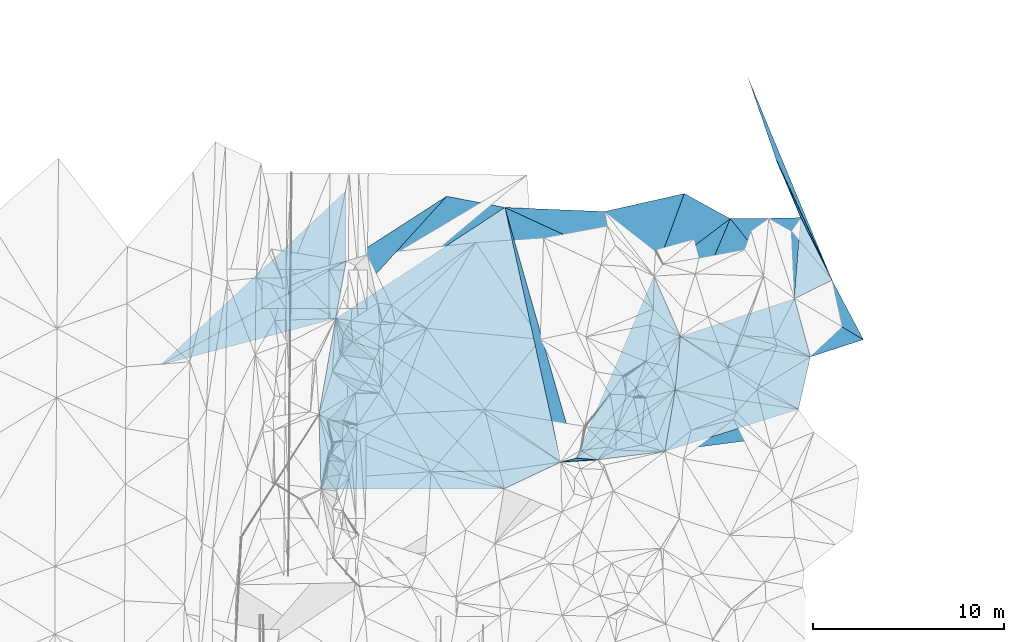
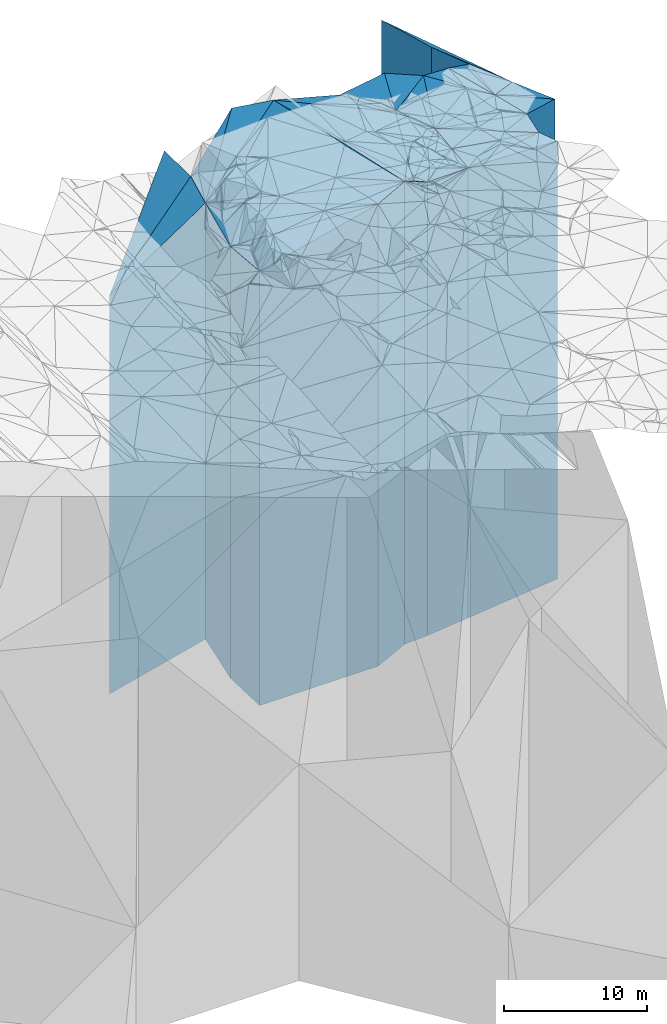
# One storey, part 275 of 275: 32 plates.
"""IFC2X3 building model written with IfcOpenShell, lengths in millimetres."""

from ifc_helpers import new_model, si_unit, frame, origin_with_axes, place, context, subcontext, project, spatial, faceted_brep, material, type_object, element, save


model = new_model("IFC2X3")

# Units and contexts
model_context = context("Model", 3, precision=1e-05, world=origin_with_axes())
body_context = subcontext(model_context, "Body", "Model", "MODEL_VIEW")
ifc_project = project(units=[si_unit("LENGTHUNIT", "METRE", prefix="MILLI"), si_unit("AREAUNIT", "SQUARE_METRE"), si_unit("VOLUMEUNIT", "CUBIC_METRE"), si_unit("MASSUNIT", "GRAM", prefix="KILO"), si_unit("TIMEUNIT", "SECOND"), si_unit("PLANEANGLEUNIT", "RADIAN"), si_unit("SOLIDANGLEUNIT", "STERADIAN"), si_unit("THERMODYNAMICTEMPERATUREUNIT", "DEGREE_CELSIUS"), si_unit("LUMINOUSINTENSITYUNIT", "LUMEN")], contexts=[model_context])

# Site, building, storey
site_placement = place(None, origin_with_axes())
site = spatial("IfcSite", under=ifc_project, at=site_placement, CompositionType="ELEMENT")
building_placement = place(site_placement, origin_with_axes())
building = spatial("IfcBuilding", under=site, at=building_placement, Name="Undefined", CompositionType="ELEMENT")
storey_placement = place(building_placement, origin_with_axes())
storey = spatial("IfcBuildingStorey", under=building, at=storey_placement, Name="Undefined", CompositionType="ELEMENT", Elevation=0.0)

# Plates
ifc_material = material()
plate_type_1 = type_object("IfcPlateType", PredefinedType="NOTDEFINED")
plate_1_placement = place(storey_placement, frame((-53566.479174385, 132362.836800441, 26452.0), z_axis=(-0.548276339935067, 0.83629722890095, 0.0), x_axis=(0.836297228900951, 0.548276339935064, 0.0)))
element("IfcPlate", 1, at=plate_1_placement, inside=storey, type_object=plate_type_1, material=ifc_material, Name="00", context=body_context, shape_type="Brep", body=[
    faceted_brep([(7.27595761418343e-12, -18624.0, 0.0), (8355.69726562502, -20827.0, 2159.91455078128), (8355.69726562502, 18624.0, 2159.91455078128), (7.27595761418343e-12, 18624.0, 0.0), (10578.91796875, -20800.0, 7.26431608200073e-08), (10578.91796875, 18624.0, 7.26431608200073e-08)], [[[0, 1, 2, 3]], [[1, 4, 5, 2]], [[4, 0, 3, 5]], [[5, 3, 2]], [[4, 1, 0]]]),
])
plate_type_2 = type_object("IfcPlateType", PredefinedType="NOTDEFINED")
plate_2_placement = place(storey_placement, frame((-36935.1244912105, 134576.584392749, 26764.5), z_axis=(-0.794915679662907, -0.606719920742726, 0.0), x_axis=(-0.606719920742717, 0.794915679662913, 0.0)))
element("IfcPlate", 2, at=plate_2_placement, inside=storey, type_object=plate_type_2, material=ifc_material, Name="00", context=body_context, shape_type="Brep", body=[
    faceted_brep([(1.45519152283669e-11, -18936.5, 1.45519152283669e-11), (7573.75439453131, -20487.5, 4011.85644531251), (7573.75439453131, 18936.5, 4011.85644531251), (1.45519152283669e-11, 18936.5, 1.45519152283669e-11), (4245.28759765628, -19233.5, -3.83515725843608e-08), (4245.28759765628, 18936.5, -3.83515725843608e-08)], [[[0, 1, 2, 3]], [[1, 4, 5, 2]], [[4, 0, 3, 5]], [[5, 3, 2]], [[4, 1, 0]]]),
])
plate_type_3 = type_object("IfcPlateType", PredefinedType="NOTDEFINED")
plate_3_placement = place(storey_placement, frame((-40995.6410742403, 125072.745480029, 26764.5), z_axis=(-0.91958438107363, 0.392892563031459, 0.0), x_axis=(0.392892563031458, 0.91958438107363, 0.0)))
element("IfcPlate", 3, at=plate_3_placement, inside=storey, type_object=plate_type_3, material=ifc_material, Name="00", context=body_context, shape_type="Brep", body=[
    faceted_brep([(1.45519152283669e-11, -20229.5, 0.0), (10574.5791015625, -20487.5, 8567.33984375), (10574.5791015625, 18936.5, 8567.33984375), (1.45519152283669e-11, 18936.5, 1.45519152283669e-11), (10334.9287109375, -18936.5, -2.43016984313726e-08), (10334.9287109375, 18936.5, -2.43016984313726e-08)], [[[0, 1, 2, 3]], [[1, 4, 5, 2]], [[4, 0, 3, 5]], [[5, 3, 2]], [[4, 1, 0]]]),
])
plate_type_4 = type_object("IfcPlateType", PredefinedType="NOTDEFINED")
plate_4_placement = place(storey_placement, frame((-39510.8249188139, 137951.229901132, 26764.5), z_axis=(0.794915679662907, 0.606719920742726, 0.0), x_axis=(0.606719920742718, -0.794915679662913, 0.0)))
element("IfcPlate", 4, at=plate_4_placement, inside=storey, type_object=plate_type_4, material=ifc_material, Name="00", context=body_context, shape_type="Brep", body=[
    faceted_brep([(0.0, -19233.5, 0.0), (1781.27355957034, -19061.5, 3881.42260742187), (1781.27355957034, 18936.5, 3881.42260742187), (1.45519152283669e-11, 18936.5, 1.45519152283669e-11), (4245.28759765625, -18936.5, -3.83515725843608e-08), (4245.28759765628, 18936.5, -3.83515725843608e-08)], [[[0, 1, 2, 3]], [[1, 4, 5, 2]], [[4, 0, 3, 5]], [[5, 3, 2]], [[4, 1, 0]]]),
])
plate_type_5 = type_object("IfcPlateType", PredefinedType="NOTDEFINED")
plate_5_placement = place(storey_placement, frame((-40995.6410742403, 125072.745480029, 26756.5), z_axis=(-0.759601874078895, 0.650388340067556, 0.0), x_axis=(0.650388340067554, 0.759601874078897, 0.0)))
element("IfcPlate", 5, at=plate_5_placement, inside=storey, type_object=plate_type_5, material=ifc_material, Name="00", context=body_context, shape_type="Brep", body=[
    faceted_brep([(0.0, -20237.5, 0.0), (9860.04687499999, -18944.5, 3096.81005859376), (9860.04687499999, 18928.5, 3096.81005859376), (0.0, 18928.5, 0.0), (8366.82421875, -18928.5, 2.24681571125984e-08), (8366.82421875, 18928.5, 2.24681571125984e-08)], [[[0, 1, 2, 3]], [[1, 4, 5, 2]], [[4, 0, 3, 5]], [[5, 3, 2]], [[4, 1, 0]]]),
])
plate_type_6 = type_object("IfcPlateType", PredefinedType="NOTDEFINED")
plate_6_placement = place(storey_placement, frame((-32940.8125849444, 137578.260823589, 26703.0), z_axis=(-0.47906004898783, -0.877782130977715, 0.0), x_axis=(-0.87778213097771, 0.479060048987838, 0.0)))
element("IfcPlate", 6, at=plate_6_placement, inside=storey, type_object=plate_type_6, material=ifc_material, Name="00", context=body_context, shape_type="Brep", body=[
    faceted_brep([(-1.45519152283669e-11, -18875.0, 1.45519152283669e-11), (2068.15234375003, -18998.0, 4548.33300781251), (2068.15234375003, 18875.0, 4548.33300781251), (-1.45519152283669e-11, 18875.0, 1.45519152283669e-11), (2738.57763671874, -19123.0, -8.55652615427971e-09), (2738.57763671874, 18875.0, -8.55652615427971e-09)], [[[0, 1, 2, 3]], [[1, 4, 5, 2]], [[4, 0, 3, 5]], [[5, 3, 2]], [[4, 1, 0]]]),
])
plate_type_7 = type_object("IfcPlateType", PredefinedType="NOTDEFINED")
plate_7_placement = place(storey_placement, frame((-40995.6410742403, 125072.745480029, 26756.5), z_axis=(-0.566081725886953, 0.824349124835375, 0.0), x_axis=(0.824349124835376, 0.566081725886952, 0.0)))
element("IfcPlate", 7, at=plate_7_placement, inside=storey, type_object=plate_type_7, material=ifc_material, Name="00", context=body_context, shape_type="Brep", body=[
    faceted_brep([(0.0, -20237.5, 0.0), (8083.55566406249, -18928.5, 2158.67578125001), (8083.55566406249, 18928.5, 2158.67578125001), (0.0, 18928.5, 0.0), (6275.57763671875, -19013.5, 3.72529029846191e-09), (6275.57763671875, 18928.5, 3.72529029846191e-09)], [[[0, 1, 2, 3]], [[1, 4, 5, 2]], [[4, 0, 3, 5]], [[5, 3, 2]], [[4, 1, 0]]]),
])
plate_type_8 = type_object("IfcPlateType", PredefinedType="NOTDEFINED")
plate_8_placement = place(storey_placement, frame((-29589.1900739562, 133400.823984589, 26555.0), z_axis=(-0.779987011303419, -0.625795703243447, 0.0), x_axis=(-0.625795703243441, 0.779987011303424, 0.0)))
element("IfcPlate", 8, at=plate_8_placement, inside=storey, type_object=plate_type_8, material=ifc_material, Name="00", context=body_context, shape_type="Brep", body=[
    faceted_brep([(0.0, -18727.0, -7.27595761418343e-12), (2194.10473632818, -19130.0, 5886.89892578126), (2194.10473632818, 18727.0, 5886.89892578126), (0.0, 18727.0, -7.27595761418343e-12), (5355.77734375001, -19023.0, -3.19414539262652e-09), (5355.77734375001, 18727.0, -3.19414539262652e-09)], [[[0, 1, 2, 3]], [[1, 4, 5, 2]], [[4, 0, 3, 5]], [[5, 3, 2]], [[4, 1, 0]]]),
])
plate_type_9 = type_object("IfcPlateType", PredefinedType="NOTDEFINED")
plate_9_placement = place(storey_placement, frame((-39883.2084587628, 124975.284328682, 26799.0), z_axis=(-0.124028560063725, 0.992278648509842, 0.0), x_axis=(0.992278648509842, 0.124028560063727, 0.0)))
element("IfcPlate", 9, at=plate_9_placement, inside=storey, type_object=plate_type_9, material=ifc_material, Name="00", context=body_context, shape_type="Brep", body=[
    faceted_brep([(-3.63797880709171e-12, -19758.0, 1.45519152283669e-11), (4482.17724609374, -18971.0, 3118.10888671876), (4482.17724609374, 18971.0, 3118.10888671876), (0.0, 18971.0, 0.0), (3547.11865234375, -19467.0, -5.4424162954092e-09), (3547.11865234375, 18971.0, -5.4424162954092e-09)], [[[0, 1, 2, 3]], [[1, 4, 5, 2]], [[4, 0, 3, 5]], [[5, 3, 2]], [[4, 1, 0]]]),
])
plate_type_10 = type_object("IfcPlateType", PredefinedType="NOTDEFINED")
plate_10_placement = place(storey_placement, frame((-28759.561686716, 130357.361854204, 26516.5), z_axis=(-0.964796544488598, -0.262997391133186, 0.0), x_axis=(-0.26299739113319, 0.964796544488596, 0.0)))
element("IfcPlate", 10, at=plate_10_placement, inside=storey, type_object=plate_type_10, material=ifc_material, Name="00", context=body_context, shape_type="Brep", body=[
    faceted_brep([(0.0, -18688.5, -7.27595761418343e-12), (2820.0500488281, -19168.5, 6273.58007812499), (2820.0500488281, 18688.5, 6273.58007812499), (0.0, 18688.5, -7.27595761418343e-12), (3154.51196289063, -18765.5, -2.07910488825291e-08), (3154.51196289063, 18688.5, -2.07910488825291e-08)], [[[0, 1, 2, 3]], [[1, 4, 5, 2]], [[4, 0, 3, 5]], [[5, 3, 2]], [[4, 1, 0]]]),
])
plate_type_11 = type_object("IfcPlateType", PredefinedType="NOTDEFINED")
plate_11_placement = place(storey_placement, frame((-40995.6410742403, 125072.745480029, 26799.0), z_axis=(0.0872765239759481, 0.996184123725467, 0.0), x_axis=(0.996184123725467, -0.087276523975949, 0.0)))
element("IfcPlate", 11, at=plate_11_placement, inside=storey, type_object=plate_type_11, material=ifc_material, Name="00", context=body_context, shape_type="Brep", body=[
    faceted_brep([(0.0, -20195.0, 0.0), (4843.47753906251, -18971.0, 3990.43872070313), (4843.47753906251, 18971.0, 3990.43872070313), (0.0, 18971.0, 0.0), (1116.69372558594, -19758.0, -2.29920260608196e-09), (1116.69372558594, 18971.0, -2.29920260608196e-09)], [[[0, 1, 2, 3]], [[1, 4, 5, 2]], [[4, 0, 3, 5]], [[5, 3, 2]], [[4, 1, 0]]]),
])
plate_type_12 = type_object("IfcPlateType", PredefinedType="NOTDEFINED")
plate_12_placement = place(storey_placement, frame((-44719.3596881945, 138163.007039069, 26452.0), z_axis=(0.548276339935067, -0.83629722890095, 0.0), x_axis=(-0.836297228900951, -0.548276339935064, 0.0)))
element("IfcPlate", 12, at=plate_12_placement, inside=storey, type_object=plate_type_12, material=ifc_material, Name="00", context=body_context, shape_type="Brep", body=[
    faceted_brep([(0.0, -20800.0, 0.0), (4854.34228515629, -20902.0, 12724.2294921875), (4854.34228515629, 18624.0, 12724.2294921875), (7.27595761418343e-12, 18624.0, 0.0), (10578.91796875, -18624.0, 7.26140569895506e-08), (10578.91796875, 18624.0, 7.26431608200073e-08)], [[[0, 1, 2, 3]], [[1, 4, 5, 2]], [[4, 0, 3, 5]], [[5, 3, 2]], [[4, 1, 0]]]),
])
plate_type_13 = type_object("IfcPlateType", PredefinedType="NOTDEFINED")
plate_13_placement = place(storey_placement, frame((-36363.4784590098, 125415.228335163, 26530.5), z_axis=(-0.12860231894967, 0.991696245611915, 0.0), x_axis=(0.991696245611914, 0.128602318949674, 0.0)))
element("IfcPlate", 13, at=plate_13_placement, inside=storey, type_object=plate_type_13, material=ifc_material, Name="00", context=body_context, shape_type="Brep", body=[
    faceted_brep([(-1.09139364212751e-11, -19735.5, 0.0), (7205.30517578124, -18988.5, 1284.81530761719), (7205.30517578124, 18702.5, 1284.81530761719), (-1.09139364212751e-11, 18702.5, 0.0), (7854.04980468749, -18702.5, 2.61934474110603e-09), (7854.04980468749, 18702.5, 2.61934474110603e-09)], [[[0, 1, 2, 3]], [[1, 4, 5, 2]], [[4, 0, 3, 5]], [[5, 3, 2]], [[4, 1, 0]]]),
])
plate_type_14 = type_object("IfcPlateType", PredefinedType="NOTDEFINED")
plate_14_placement = place(storey_placement, frame((-53566.479174385, 132362.836800441, 26452.0), z_axis=(0.711051871045957, 0.70313955704543, 0.0), x_axis=(0.703139557045438, -0.711051871045949, 0.0)))
element("IfcPlate", 14, at=plate_14_placement, inside=storey, type_object=plate_type_14, material=ifc_material, Name="00", context=body_context, shape_type="Brep", body=[
    faceted_brep([(7.27595761418343e-12, -18624.0, 0.0), (13606.3515625, -20902.0, 3089.33398437498), (13606.3515625, 18624.0, 3089.33398437498), (7.27595761418343e-12, 18624.0, 0.0), (12513.59375, -20847.0, 1.41219061333686e-07), (12513.59375, 18624.0, 1.41219061333686e-07)], [[[0, 1, 2, 3]], [[1, 4, 5, 2]], [[4, 0, 3, 5]], [[5, 3, 2]], [[4, 1, 0]]]),
])
plate_type_15 = type_object("IfcPlateType", PredefinedType="NOTDEFINED")
plate_15_placement = place(storey_placement, frame((-44719.3596881945, 138163.007039069, 27411.0), z_axis=(0.976796545699508, 0.214169344934118, 0.0), x_axis=(0.214169344934115, -0.976796545699509, 0.0)))
element("IfcPlate", 15, at=plate_15_placement, inside=storey, type_object=plate_type_15, material=ifc_material, Name="00", context=body_context, shape_type="Brep", body=[
    faceted_brep([(0.0, -19841.0, -1.81898940354586e-12), (13584.0283203125, -19583.0, 833.782714843745), (13584.0283203125, 19583.0, 833.782714843745), (0.0, 19583.0, -1.81898940354586e-12), (13618.76171875, -19943.0, -1.63783624884672e-07), (13618.76171875, 19583.0, -1.63783624884672e-07)], [[[0, 1, 2, 3]], [[1, 4, 5, 2]], [[4, 0, 3, 5]], [[5, 3, 2]], [[4, 1, 0]]]),
])
plate_type_16 = type_object("IfcPlateType", PredefinedType="NOTDEFINED")
plate_16_placement = place(storey_placement, frame((-36935.1244912105, 134576.584392749, 26703.0), z_axis=(0.915756250462035, 0.401734352202691, 0.0), x_axis=(0.401734352202691, -0.915756250462034, 0.0)))
element("IfcPlate", 16, at=plate_16_placement, inside=storey, type_object=plate_type_16, material=ifc_material, Name="00", context=body_context, shape_type="Brep", body=[
    faceted_brep([(-2.91038304567337e-11, -18998.0, 2.18278728425503e-11), (-1144.15161132815, -18875.0, 4863.69287109376), (-1144.15161132815, 18875.0, 4863.69287109376), (-1.45519152283669e-11, 18875.0, 1.45519152283669e-11), (3438.01464843747, -18982.0, -3.75548552256078e-08), (3438.01464843747, 18875.0, -3.75548552256078e-08)], [[[0, 1, 2, 3]], [[1, 4, 5, 2]], [[4, 0, 3, 5]], [[5, 3, 2]], [[4, 1, 0]]]),
])
plate_type_17 = type_object("IfcPlateType", PredefinedType="NOTDEFINED")
plate_17_placement = place(storey_placement, frame((-47762.862830299, 138750.398411154, 26452.0), z_axis=(0.542053619135628, -0.84034390221026, 0.0), x_axis=(-0.840343902210261, -0.542053619135627, 0.0)))
element("IfcPlate", 17, at=plate_17_placement, inside=storey, type_object=plate_type_17, material=ifc_material, Name="00", context=body_context, shape_type="Brep", body=[
    faceted_brep([(7.27595761418343e-12, -20827.0, -2.91038304567337e-11), (8339.43457031251, -18624.0, 2221.8771972656), (8339.43457031251, 18624.0, 2221.8771972656), (7.27595761418343e-12, 18624.0, 0.0), (6259.55810546875, -18888.0, 2.12749000638723e-08), (6259.55810546875, 18624.0, 2.12749000638723e-08)], [[[0, 1, 2, 3]], [[1, 4, 5, 2]], [[4, 0, 3, 5]], [[5, 3, 2]], [[4, 1, 0]]]),
])
plate_type_18 = type_object("IfcPlateType", PredefinedType="NOTDEFINED")
plate_18_placement = place(storey_placement, frame((-53023.0441351296, 135357.382401715, 24844.0), z_axis=(-0.999999943950796, 0.000334810999991428, 0.0), x_axis=(0.000334810999983303, 0.999999943950796, 0.0)))
element("IfcPlate", 18, at=plate_18_placement, inside=storey, type_object=plate_type_18, material=ifc_material, Name="00", context=body_context, shape_type="Brep", body=[
    faceted_brep([(2.91038304567337e-11, -20496.0, 2.91038304567337e-11), (-5425.01220703131, -17016.0, 9688.33691406251), (-5425.01220703131, 17016.0, 9688.33691406251), (2.91038304567337e-11, 17016.0, -5.6843418860808e-12), (3684.18798828128, -20460.0, 4.30445652455091e-08), (3684.18798828128, 17016.0, 4.30445652455091e-08)], [[[0, 1, 2, 3]], [[1, 4, 5, 2]], [[4, 0, 3, 5]], [[5, 3, 2]], [[4, 1, 0]]]),
])
plate_type_19 = type_object("IfcPlateType", PredefinedType="NOTDEFINED")
plate_19_placement = place(storey_placement, frame((-39883.2084587628, 124975.284328682, 27192.5), z_axis=(-0.0872765239759481, -0.996184123725467, 0.0), x_axis=(-0.996184123725467, 0.0872765239759485, 0.0)))
element("IfcPlate", 19, at=plate_19_placement, inside=storey, type_object=plate_type_19, material=ifc_material, Name="00", context=body_context, shape_type="Brep", body=[
    faceted_brep([(0.0, -19364.5, 0.0), (1902.06579589844, -20161.5, 282.118530273438), (1902.06579589844, 19364.5, 282.118530273438), (0.0, 19364.5, 0.0), (1116.69372558594, -19801.5, -2.2846506908536e-09), (1116.69372558594, 19364.5, -2.2846506908536e-09)], [[[0, 1, 2, 3]], [[1, 4, 5, 2]], [[4, 0, 3, 5]], [[5, 3, 2]], [[4, 1, 0]]]),
])
plate_type_20 = type_object("IfcPlateType", PredefinedType="NOTDEFINED")
plate_20_placement = place(storey_placement, frame((-30532.1570825837, 140639.818543272, 26474.5), z_axis=(0.920549248499783, 0.39062652378773, 0.0), x_axis=(0.390626523787737, -0.920549248499779, 0.0)))
element("IfcPlate", 20, at=plate_20_placement, inside=storey, type_object=plate_type_20, material=ifc_material, Name="00", context=body_context, shape_type="Brep", body=[
    faceted_brep([(0.0, -18821.5, -3.63797880709171e-12), (6909.39111328125, -18646.5, 225.707504272454), (6909.39111328125, 18646.5, 225.707504272454), (0.0, 18646.5, -3.63797880709171e-12), (3265.36767578125, -18768.5, -2.58587533608079e-08), (3265.36767578125, 18646.5, -2.58587533608079e-08)], [[[0, 1, 2, 3]], [[1, 4, 5, 2]], [[4, 0, 3, 5]], [[5, 3, 2]], [[4, 1, 0]]]),
])
plate_type_21 = type_object("IfcPlateType", PredefinedType="NOTDEFINED")
plate_21_placement = place(storey_placement, frame((-25983.6102273337, 131257.863656064, 26397.0), z_axis=(-0.884319403766347, -0.466882417876634, 0.0), x_axis=(-0.46688241787664, 0.884319403766344, 0.0)))
element("IfcPlate", 21, at=plate_21_placement, inside=storey, type_object=plate_type_21, material=ifc_material, Name="00", context=body_context, shape_type="Brep", body=[
    faceted_brep([(0.0, -18569.0, -7.27595761418343e-12), (3578.44311523438, -18885.0, 2187.97363281249), (3578.44311523438, 18569.0, 2187.97363281249), (0.0, 18569.0, -7.27595761418343e-12), (3516.4755859375, -18724.0, 1.54250301420689e-08), (3516.4755859375, 18569.0, 1.54250301420689e-08)], [[[0, 1, 2, 3]], [[1, 4, 5, 2]], [[4, 0, 3, 5]], [[5, 3, 2]], [[4, 1, 0]]]),
])
plate_type_22 = type_object("IfcPlateType", PredefinedType="NOTDEFINED")
plate_22_placement = place(storey_placement, frame((-27625.3908153063, 134367.551180713, 26474.5), z_axis=(-0.894639716906714, -0.446788290953417, 0.0), x_axis=(-0.446788290953413, 0.894639716906716, 0.0)))
element("IfcPlate", 22, at=plate_22_placement, inside=storey, type_object=plate_type_22, material=ifc_material, Name="00", context=body_context, shape_type="Brep", body=[
    faceted_brep([(0.0, -18646.5, 0.0), (12.5299682617479, -18807.5, 2188.81518554688), (12.5299682617479, 18646.5, 2188.81518554688), (0.0, 18646.5, -3.63797880709171e-12), (3651.00659179688, -18768.5, -4.15020622313023e-08), (3651.00659179688, 18646.5, -4.15020622313023e-08)], [[[0, 1, 2, 3]], [[1, 4, 5, 2]], [[4, 0, 3, 5]], [[5, 3, 2]], [[4, 1, 0]]]),
])
plate_type_23 = type_object("IfcPlateType", PredefinedType="NOTDEFINED")
plate_23_placement = place(storey_placement, frame((-27625.3908153063, 134367.551180713, 26474.5), z_axis=(-0.923771114001947, -0.382945073000817, 0.0), x_axis=(-0.382945073000808, 0.923771114001951, 0.0)))
element("IfcPlate", 23, at=plate_23_placement, inside=storey, type_object=plate_type_23, material=ifc_material, Name="00", context=body_context, shape_type="Brep", body=[
    faceted_brep([(0.0, -18646.5, 0.0), (6907.27099609375, -18821.5, 283.252838134762), (6907.27099609375, 18646.5, 283.252838134762), (0.0, 18646.5, -3.63797880709171e-12), (11528.138671875, -19020.5, 7.55280780140311e-08), (11528.138671875, 18646.5, 7.55280780140311e-08)], [[[0, 1, 2, 3]], [[1, 4, 5, 2]], [[4, 0, 3, 5]], [[5, 3, 2]], [[4, 1, 0]]]),
])
plate_type_24 = type_object("IfcPlateType", PredefinedType="NOTDEFINED")
plate_24_placement = place(storey_placement, frame((-35553.955945229, 131428.201085782, 26673.5), z_axis=(0.99544609314663, -0.0953261540140512, 0.0), x_axis=(-0.095326154014042, -0.995446093146631, 0.0)))
element("IfcPlate", 24, at=plate_24_placement, inside=storey, type_object=plate_type_24, material=ifc_material, Name="00", context=body_context, shape_type="Brep", body=[
    faceted_brep([(0.0, -19011.5, 0.0), (3206.61572265619, -18845.5, 6506.02392578124), (3206.61572265619, 18845.5, 6506.02392578124), (0.0, 18845.5, 0.0), (2815.78881835938, -19096.5, -3.75439412891865e-08), (2815.78881835938, 18845.5, -3.75439412891865e-08)], [[[0, 1, 2, 3]], [[1, 4, 5, 2]], [[4, 0, 3, 5]], [[5, 3, 2]], [[4, 1, 0]]]),
])
plate_type_25 = type_object("IfcPlateType", PredefinedType="NOTDEFINED")
plate_25_placement = place(storey_placement, frame((-35822.3742527694, 128625.235225808, 26673.5), z_axis=(0.986088213841215, -0.166222845973238, 0.0), x_axis=(-0.166222845973234, -0.986088213841215, 0.0)))
element("IfcPlate", 25, at=plate_25_placement, inside=storey, type_object=plate_type_25, material=ifc_material, Name="00", context=body_context, shape_type="Brep", body=[
    faceted_brep([(-1.45519152283669e-11, -19096.5, -7.27595761418343e-12), (-75.1311569214304, -18845.5, 6517.31884765625), (-75.1311569214304, 18845.5, 6517.31884765625), (0.0, 18845.5, 0.0), (3255.29394531249, -19592.5, 1.14596332423389e-08), (3255.29394531249, 18845.5, 1.14596332423389e-08)], [[[0, 1, 2, 3]], [[1, 4, 5, 2]], [[4, 0, 3, 5]], [[5, 3, 2]], [[4, 1, 0]]]),
])
plate_type_26 = type_object("IfcPlateType", PredefinedType="NOTDEFINED")
plate_26_placement = place(storey_placement, frame((-30940.8445646839, 137597.700935096, 26535.5), z_axis=(0.951852759156451, 0.306555582050387, 0.0), x_axis=(0.306555582050387, -0.951852759156451, 0.0)))
element("IfcPlate", 26, at=plate_26_placement, inside=storey, type_object=plate_type_26, material=ifc_material, Name="00", context=body_context, shape_type="Brep", body=[
    faceted_brep([(0.0, -18964.5, -3.63797880709171e-12), (481.865478515625, -18707.5, 1614.22875976563), (481.865478515625, 18707.5, 1614.22875976563), (0.0, 18707.5, -3.63797880709171e-12), (4409.166015625, -18746.5, 9.02582542039454e-09), (4409.166015625, 18707.5, 9.02582542039454e-09)], [[[0, 1, 2, 3]], [[1, 4, 5, 2]], [[4, 0, 3, 5]], [[5, 3, 2]], [[4, 1, 0]]]),
])
plate_type_27 = type_object("IfcPlateType", PredefinedType="NOTDEFINED")
plate_27_placement = place(storey_placement, frame((-44767.6767352506, 123465.022875825, 26282.5), z_axis=(-0.71105187104595, -0.703139557045438, 0.0), x_axis=(-0.703139557045438, 0.711051871045949, 0.0)))
element("IfcPlate", 27, at=plate_27_placement, inside=storey, type_object=plate_type_27, material=ifc_material, Name="00", context=body_context, shape_type="Brep", body=[
    faceted_brep([(0.0, -21016.5, 1.45519152283669e-11), (9561.93945312499, -18454.5, 4154.87597656252), (9561.93945312499, 18454.5, 4154.87597656252), (0.0, 18454.5, 1.45519152283669e-11), (12513.59375, -18793.5, 7.58154783397913e-08), (12513.59375, 18454.5, 7.58154783397913e-08)], [[[0, 1, 2, 3]], [[1, 4, 5, 2]], [[4, 0, 3, 5]], [[5, 3, 2]], [[4, 1, 0]]]),
])
plate_type_28 = type_object("IfcPlateType", PredefinedType="NOTDEFINED")
plate_28_placement = place(storey_placement, frame((-44767.6767352506, 123465.022875825, 26282.5), z_axis=(-0.371927538048322, -0.928261766120589, 0.0), x_axis=(-0.92826176612059, 0.371927538048317, 0.0)))
element("IfcPlate", 28, at=plate_28_placement, inside=storey, type_object=plate_type_28, material=ifc_material, Name="00", context=body_context, shape_type="Brep", body=[
    faceted_brep([(0.0, -21016.5, 1.45519152283669e-11), (8874.31152343749, -18646.5, 3577.27246093749), (8874.31152343749, 18454.5, 3577.27246093749), (0.0, 18454.5, 1.45519152283669e-11), (10425.626953125, -18454.5, 4.95201675221324e-08), (10425.626953125, 18454.5, 4.95201675221324e-08)], [[[0, 1, 2, 3]], [[1, 4, 5, 2]], [[4, 0, 3, 5]], [[5, 3, 2]], [[4, 1, 0]]]),
])
plate_type_29 = type_object("IfcPlateType", PredefinedType="NOTDEFINED")
plate_29_placement = place(storey_placement, frame((-29589.1900739562, 133400.823984589, 26397.0), z_axis=(0.964796544488594, 0.262997391133199, 0.0), x_axis=(0.262997391133188, -0.964796544488597, 0.0)))
element("IfcPlate", 29, at=plate_29_placement, inside=storey, type_object=plate_type_29, material=ifc_material, Name="00", context=body_context, shape_type="Brep", body=[
    faceted_brep([(2.91038304567337e-11, -18885.0, 1.81898940354586e-12), (3015.77880859378, -18569.0, 2915.05810546875), (3015.77880859378, 18569.0, 2915.05810546875), (0.0, 18569.0, -7.27595761418343e-12), (3154.51196289063, -18808.0, -1.17270246846601e-08), (3154.51196289063, 18569.0, -1.17270246846601e-08)], [[[0, 1, 2, 3]], [[1, 4, 5, 2]], [[4, 0, 3, 5]], [[5, 3, 2]], [[4, 1, 0]]]),
])
plate_type_30 = type_object("IfcPlateType", PredefinedType="NOTDEFINED")
plate_30_placement = place(storey_placement, frame((-29589.1900739562, 133400.823984589, 26555.0), z_axis=(-0.951852759156451, -0.306555582050387, 0.0), x_axis=(-0.306555582050387, 0.951852759156451, 0.0)))
element("IfcPlate", 30, at=plate_30_placement, inside=storey, type_object=plate_type_30, material=ifc_material, Name="00", context=body_context, shape_type="Brep", body=[
    faceted_brep([(0.0, -18727.0, -7.27595761418343e-12), (5003.76318359375, -19023.0, 1909.63452148438), (5003.76318359375, 18727.0, 1909.63452148438), (0.0, 18727.0, -7.27595761418343e-12), (4409.166015625, -18945.0, 9.01854946278036e-09), (4409.166015625, 18727.0, 9.01854946278036e-09)], [[[0, 1, 2, 3]], [[1, 4, 5, 2]], [[4, 0, 3, 5]], [[5, 3, 2]], [[4, 1, 0]]]),
])
plate_type_31 = type_object("IfcPlateType", PredefinedType="NOTDEFINED")
plate_31_placement = place(storey_placement, frame((-62713.1966920055, 129935.61438524, 24844.0), z_axis=(-0.256488231912941, 0.966547353671911, 0.0), x_axis=(0.966547353671912, 0.256488231912937, 0.0)))
element("IfcPlate", 31, at=plate_31_placement, inside=storey, type_object=plate_type_31, material=ifc_material, Name="00", context=body_context, shape_type="Brep", body=[
    faceted_brep([(0.0, -17016.0, 0.0), (10756.611328125, -20496.0, 2754.9853515625), (10756.611328125, 17016.0, 2754.9853515625), (2.91038304567337e-11, 17016.0, -5.6843418860808e-12), (9463.29003906249, -20232.0, -9.48784872889519e-09), (9463.29003906249, 17016.0, -9.48784872889519e-09)], [[[0, 1, 2, 3]], [[1, 4, 5, 2]], [[4, 0, 3, 5]], [[5, 3, 2]], [[4, 1, 0]]]),
])
plate_type_32 = type_object("IfcPlateType", PredefinedType="NOTDEFINED")
plate_32_placement = place(storey_placement, frame((-29383.2344096749, 127615.993886449, 26516.5), z_axis=(-0.975084055169594, 0.221835717038578, 0.0), x_axis=(0.221835717038584, 0.975084055169593, 0.0)))
element("IfcPlate", 32, at=plate_32_placement, inside=storey, type_object=plate_type_32, material=ifc_material, Name="00", context=body_context, shape_type="Brep", body=[
    faceted_brep([(-1.45519152283669e-11, -19002.5, 0.0), (2348.33593750001, -19168.5, 6862.65576171874), (2348.33593750001, 18688.5, 6862.65576171874), (0.0, 18688.5, -7.27595761418343e-12), (2811.41699218749, -18688.5, -6.06814865022898e-09), (2811.41699218749, 18688.5, -6.06814865022898e-09)], [[[0, 1, 2, 3]], [[1, 4, 5, 2]], [[4, 0, 3, 5]], [[5, 3, 2]], [[4, 1, 0]]]),
])

save(model, "model.ifc")
